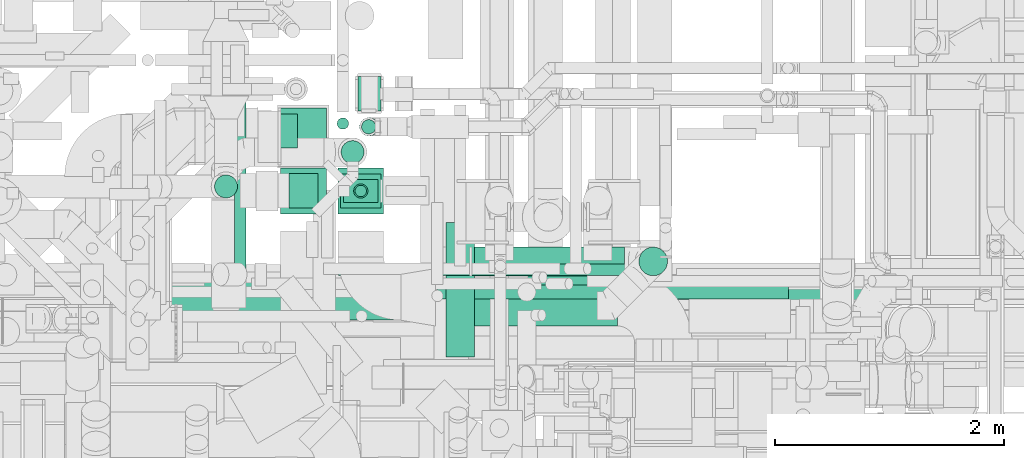
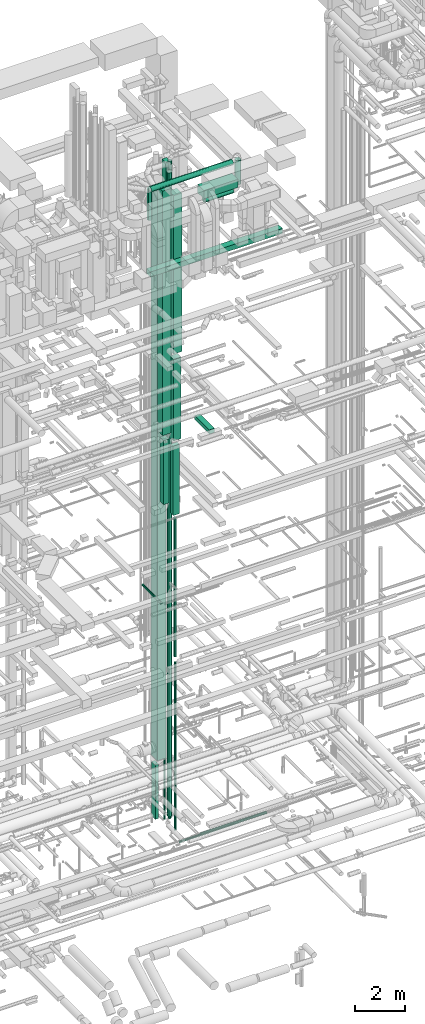
# One storey, part 55 of 337: 24 flow segments.
"""IFC2X3 building model written with IfcOpenShell, lengths in millimetres."""

from ifc_helpers import new_model, entity, si_unit, converted_unit, derived_unit, direction, frame, origin, origin_2d_with_axis, place, context, subcontext, project, spatial, rectangle, circle, extrude, type_object, element, save


model = new_model("IFC2X3")

# Units and contexts
model_context = context("Model", 3, precision=0.01, world=origin(), true_north=direction((6.12303176911189e-17, 1.0)))
body_context = subcontext(model_context, "Body", "Model", "MODEL_VIEW")
ifc_project = project(units=[si_unit("LENGTHUNIT", "METRE", prefix="MILLI"), si_unit("AREAUNIT", "SQUARE_METRE"), si_unit("VOLUMEUNIT", "CUBIC_METRE"), converted_unit("PLANEANGLEUNIT", "DEGREE", entity("IfcRatioMeasure", 0.0174532925199433), si_unit("PLANEANGLEUNIT", "RADIAN"), dimensions=[0, 0, 0, 0, 0, 0, 0]), si_unit("MASSUNIT", "GRAM", prefix="KILO"), derived_unit("MASSDENSITYUNIT", [(si_unit("MASSUNIT", "GRAM", prefix="KILO"), 1), (si_unit("LENGTHUNIT", "METRE"), -3)]), derived_unit("MOMENTOFINERTIAUNIT", [(si_unit("LENGTHUNIT", "METRE"), 4)]), si_unit("TIMEUNIT", "SECOND"), si_unit("FREQUENCYUNIT", "HERTZ"), si_unit("THERMODYNAMICTEMPERATUREUNIT", "DEGREE_CELSIUS"), derived_unit("THERMALTRANSMITTANCEUNIT", [(si_unit("MASSUNIT", "GRAM", prefix="KILO"), 1), (si_unit("THERMODYNAMICTEMPERATUREUNIT", "KELVIN"), -1), (si_unit("TIMEUNIT", "SECOND"), -3)]), derived_unit("VOLUMETRICFLOWRATEUNIT", [(si_unit("LENGTHUNIT", "METRE"), 3), (si_unit("TIMEUNIT", "SECOND"), -1)]), derived_unit("MASSFLOWRATEUNIT", [(si_unit("MASSUNIT", "GRAM", prefix="KILO"), 1), (si_unit("TIMEUNIT", "SECOND"), -1)]), derived_unit("ROTATIONALFREQUENCYUNIT", [(si_unit("TIMEUNIT", "SECOND"), -1)]), si_unit("ELECTRICCURRENTUNIT", "AMPERE"), si_unit("ELECTRICVOLTAGEUNIT", "VOLT"), si_unit("POWERUNIT", "WATT"), si_unit("FORCEUNIT", "NEWTON", prefix="KILO"), si_unit("ILLUMINANCEUNIT", "LUX"), si_unit("LUMINOUSFLUXUNIT", "LUMEN"), si_unit("LUMINOUSINTENSITYUNIT", "CANDELA"), derived_unit("USERDEFINED", [(si_unit("MASSUNIT", "GRAM", prefix="KILO"), -1), (si_unit("LENGTHUNIT", "METRE"), -2), (si_unit("TIMEUNIT", "SECOND"), 3), (si_unit("LUMINOUSFLUXUNIT", "LUMEN"), 1)]), derived_unit("LINEARVELOCITYUNIT", [(si_unit("LENGTHUNIT", "METRE"), 1), (si_unit("TIMEUNIT", "SECOND"), -1)]), si_unit("PRESSUREUNIT", "PASCAL"), derived_unit("USERDEFINED", [(si_unit("LENGTHUNIT", "METRE"), -2), (si_unit("MASSUNIT", "GRAM", prefix="KILO"), 1), (si_unit("TIMEUNIT", "SECOND"), -2)]), derived_unit("LINEARFORCEUNIT", [(si_unit("MASSUNIT", "GRAM", prefix="KILO"), 1), (si_unit("LENGTHUNIT", "METRE"), 1), (si_unit("TIMEUNIT", "SECOND"), -2), (si_unit("LENGTHUNIT", "METRE"), -1)]), derived_unit("PLANARFORCEUNIT", [(si_unit("MASSUNIT", "GRAM", prefix="KILO"), 1), (si_unit("LENGTHUNIT", "METRE"), 1), (si_unit("TIMEUNIT", "SECOND"), -2), (si_unit("LENGTHUNIT", "METRE"), -2)])], contexts=[model_context])

# Site, building, storey
site_placement = place(None, origin())
site = spatial("IfcSite", under=ifc_project, at=site_placement, CompositionType="ELEMENT")
building_placement = place(site_placement, origin())
building = spatial("IfcBuilding", under=site, at=building_placement, CompositionType="ELEMENT")
storey_placement = place(building_placement, origin())
storey = spatial("IfcBuildingStorey", under=building, at=storey_placement, CompositionType="ELEMENT", Elevation=0.0)

# Flow segments
duct_segment_type_1 = type_object("IfcDuctSegmentType", PredefinedType="NOTDEFINED")
flow_segment_1_placement = place(storey_placement, frame((59455.69, 11664.2, 14862.21)))
element("IfcFlowSegment", 1, at=flow_segment_1_placement, inside=storey, type_object=duct_segment_type_1, context=body_context, shape_type="SweptSolid", body=[
    extrude(rectangle(XDim=300.000000000001, YDim=199.999999999998, at=origin_2d_with_axis()), frame((100.0, 150.0, 0.0), z_axis=(0.0, 0.0, 1.0), x_axis=(0.0, -1.0, 0.0)), (0.0, 0.0, 1.0), 16612.7853303961),
])
flow_segment_2_placement = place(storey_placement, frame((59330.56, 10864.63, 14665.0)))
element("IfcFlowSegment", 2, at=flow_segment_2_placement, inside=storey, type_object=duct_segment_type_1, context=body_context, shape_type="SweptSolid", body=[
    extrude(rectangle(XDim=200.000000000002, YDim=300.000000000001, at=origin_2d_with_axis()), frame((150.0, 100.0, 0.0), z_axis=(0.0, 0.0, 1.0), x_axis=(0.0, 1.0, 0.0)), (0.0, 0.0, 1.0), 3400.00000000005),
])
flow_segment_3_placement = place(storey_placement, frame((59305.56, 10814.63, 18365.0)))
element("IfcFlowSegment", 3, at=flow_segment_3_placement, inside=storey, type_object=duct_segment_type_1, context=body_context, shape_type="SweptSolid", body=[
    extrude(rectangle(XDim=299.999999999999, YDim=349.999999999998, at=origin_2d_with_axis()), frame((175.0, 150.0, 0.0), z_axis=(0.0, 0.0, 1.0), x_axis=(0.0, -1.0, 0.0)), (0.0, 0.0, 1.0), 4000.0),
])
flow_segment_4_placement = place(storey_placement, frame((59280.56, 10764.63, 22665.0)))
element("IfcFlowSegment", 4, at=flow_segment_4_placement, inside=storey, type_object=duct_segment_type_1, context=body_context, shape_type="SweptSolid", body=[
    extrude(rectangle(XDim=400.0, YDim=399.999999999996, at=origin_2d_with_axis()), frame((200.0, 200.0, 0.0), z_axis=(0.0, 0.0, 1.0), x_axis=(0.0, 1.0, 0.0)), (0.0, 0.0, 1.0), 7785.00000000005),
])
flow_segment_5_placement = place(storey_placement, frame((60224.84, 9515.12, 19175.0)))
element("IfcFlowSegment", 5, at=flow_segment_5_placement, inside=storey, type_object=duct_segment_type_1, context=body_context, shape_type="SweptSolid", body=[
    extrude(rectangle(XDim=1175.51081891538, YDim=250.000000000004, at=origin_2d_with_axis()), frame((125.0, 587.76, 0.0), z_axis=(0.0, 0.0, 1.0), x_axis=(0.0, -1.0, 0.0)), (0.0, 0.0, 1.0), 199.999999999998),
])
flow_segment_6_placement = place(storey_placement, frame((57735.52, 9932.41, 27500.0)))
element("IfcFlowSegment", 6, at=flow_segment_6_placement, inside=storey, type_object=duct_segment_type_1, context=body_context, shape_type="SweptSolid", body=[
    extrude(rectangle(XDim=6129.99999999986, YDim=299.999999999999, at=origin_2d_with_axis()), frame((3065.0, 150.0, 0.0)), (0.0, 0.0, 1.0), 250.000000000004),
])
flow_segment_7_placement = place(storey_placement, frame((60130.56, 9787.5, 30600.0)))
element("IfcFlowSegment", 7, at=flow_segment_7_placement, inside=storey, type_object=duct_segment_type_1, context=body_context, shape_type="SweptSolid", body=[
    extrude(rectangle(XDim=1589.47570005678, YDim=499.999999999999, at=origin_2d_with_axis()), frame((794.74, 250.0, 0.0)), (0.0, 0.0, 1.0), 399.999999999996),
])
flow_segment_8_placement = place(storey_placement, frame((58780.38, 10765.63, 18844.46)))
element("IfcFlowSegment", 8, at=flow_segment_8_placement, inside=storey, type_object=duct_segment_type_1, context=body_context, shape_type="SweptSolid", body=[
    extrude(rectangle(XDim=400.000000000007, YDim=400.0, at=origin_2d_with_axis()), frame((200.0, 200.0, 0.0)), (0.0, 0.0, 1.0), 12005.5411833054),
])
flow_segment_9_placement = place(storey_placement, frame((58779.9, 11189.32, 2620.0)))
element("IfcFlowSegment", 9, at=flow_segment_9_placement, inside=storey, type_object=duct_segment_type_1, context=body_context, shape_type="SweptSolid", body=[
    extrude(rectangle(XDim=499.999999999997, YDim=400.0, at=origin_2d_with_axis()), frame((200.01, 250.0, 0.0), z_axis=(-3.89216743378987e-07, 0.0, 1.0), x_axis=(0.0, -1.0, 0.0)), (0.0, 0.0, 1.0), 27930.0045295659),
])
flow_segment_10_placement = place(storey_placement, frame((58779.81, 11337.87, -350.0)))
element("IfcFlowSegment", 10, at=flow_segment_10_placement, inside=storey, type_object=duct_segment_type_1, context=body_context, shape_type="SweptSolid", body=[
    extrude(rectangle(XDim=149.999999999998, YDim=300.000000000001, at=origin_2d_with_axis()), frame((75.0, 150.0, 0.0)), (0.0, 0.0, 1.0), 2670.00002678592),
])
flow_segment_11_placement = place(storey_placement, frame((58855.38, 10815.63, 15400.0)))
element("IfcFlowSegment", 11, at=flow_segment_11_placement, inside=storey, type_object=duct_segment_type_1, context=body_context, shape_type="SweptSolid", body=[
    extrude(rectangle(XDim=249.999999999995, YDim=300.000000000001, at=origin_2d_with_axis()), frame((125.0, 150.0, 0.0)), (0.0, 0.0, 1.0), 3144.45879169654),
])
duct_segment_type_2 = type_object("IfcDuctSegmentType", PredefinedType="NOTDEFINED")
flow_segment_12_placement = place(storey_placement, frame((60145.15, 10019.49, -849.1)))
element("IfcFlowSegment", 12, at=flow_segment_12_placement, inside=storey, type_object=duct_segment_type_2, context=body_context, shape_type="SweptSolid", body=[
    extrude(circle(Radius=62.5, at=origin_2d_with_axis()), frame((0.0, 64.1, 64.1), z_axis=(1.0, 0.0, 0.0), x_axis=(0.0, 1.0, 0.0)), (0.0, 0.0, 1.0), 3067.9582299999),
])
flow_segment_13_placement = place(storey_placement, frame((59307.34, 11202.59, -350.0)))
element("IfcFlowSegment", 13, at=flow_segment_13_placement, inside=storey, type_object=duct_segment_type_2, context=body_context, shape_type="SweptSolid", body=[
    extrude(circle(Radius=100.0, at=origin_2d_with_axis()), frame((101.6, 101.6, 0.0), z_axis=(0.0, 0.0, 1.0), x_axis=(-1.0, 0.0, 0.0)), (0.0, 0.0, 1.0), 31619.5965842715),
])
flow_segment_14_placement = place(storey_placement, frame((59286.81, 10227.1, -1026.6)))
element("IfcFlowSegment", 14, at=flow_segment_14_placement, inside=storey, type_object=duct_segment_type_2, context=body_context, shape_type="SweptSolid", body=[
    extrude(circle(Radius=50.0, at=origin_2d_with_axis()), frame((0.0, 51.6, 51.6), z_axis=(1.0, 0.0, 0.0), x_axis=(0.0, -1.0, 0.0)), (0.0, 0.0, 1.0), 2753.45116999999),
])
flow_segment_15_placement = place(storey_placement, frame((58375.69, 10255.6, 10998.4)))
element("IfcFlowSegment", 15, at=flow_segment_15_placement, inside=storey, type_object=duct_segment_type_2, context=body_context, shape_type="SweptSolid", body=[
    extrude(circle(Radius=50.0, at=origin_2d_with_axis()), frame((51.6, 0.0, 51.6), z_axis=(0.0, 1.0, 0.0), x_axis=(1.0, 0.0, 0.0)), (0.0, 0.0, 1.0), 1498.62851561006),
])
flow_segment_16_placement = place(storey_placement, frame((59485.89, 11460.8, -660.0)))
element("IfcFlowSegment", 16, at=flow_segment_16_placement, inside=storey, type_object=duct_segment_type_2, context=body_context, shape_type="SweptSolid", body=[
    extrude(circle(Radius=62.5, at=origin_2d_with_axis()), frame((64.1, 64.1, 0.0), z_axis=(-1.77429412138521e-06, 0.0, 1.0), x_axis=(-1.0, 0.0, -1.77429412138521e-06)), (0.0, 0.0, 1.0), 3955.00000070971),
])
flow_segment_17_placement = place(storey_placement, frame((59428.96, 10913.04, -875.0)))
element("IfcFlowSegment", 17, at=flow_segment_17_placement, inside=storey, type_object=duct_segment_type_2, context=body_context, shape_type="SweptSolid", body=[
    extrude(circle(Radius=50.0, at=origin_2d_with_axis()), frame((51.6, 51.6, 0.0), z_axis=(0.0, 0.0, 1.0), x_axis=(0.0, -1.0, 0.0)), (0.0, 0.0, 1.0), 8240.00000000002),
])
flow_segment_18_placement = place(storey_placement, frame((59416.46, 10900.54, 7650.0)))
element("IfcFlowSegment", 18, at=flow_segment_18_placement, inside=storey, type_object=duct_segment_type_2, context=body_context, shape_type="SweptSolid", body=[
    extrude(circle(Radius=62.5, at=origin_2d_with_axis()), frame((64.1, 64.1, 0.0)), (0.0, 0.0, 1.0), 6815.00000000002),
])
flow_segment_19_placement = place(storey_placement, frame((57734.08, 9838.14, 31673.4)))
element("IfcFlowSegment", 19, at=flow_segment_19_placement, inside=storey, type_object=duct_segment_type_2, context=body_context, shape_type="SweptSolid", body=[
    extrude(circle(Radius=125.0, at=origin_2d_with_axis()), frame((0.0, 126.6, 126.6), z_axis=(1.0, 0.0, 0.0), x_axis=(0.0, -1.0, 0.0)), (0.0, 0.0, 1.0), 3808.88033491606),
])
flow_segment_20_placement = place(storey_placement, frame((61905.38, 10223.59, 30350.0)))
element("IfcFlowSegment", 20, at=flow_segment_20_placement, inside=storey, type_object=duct_segment_type_2, context=body_context, shape_type="SweptSolid", body=[
    extrude(circle(Radius=125.0, at=origin_2d_with_axis()), frame((126.6, 126.6, 0.0), z_axis=(0.0, 0.0, 1.0), x_axis=(0.707106781186555, -0.70710678118654, 0.0)), (0.0, 0.0, 1.0), 1200.00000000001),
])
flow_segment_21_placement = place(storey_placement, frame((60451.97, 10223.59, 29973.4)))
element("IfcFlowSegment", 21, at=flow_segment_21_placement, inside=storey, type_object=duct_segment_type_2, context=body_context, shape_type="SweptSolid", body=[
    extrude(circle(Radius=125.0, at=origin_2d_with_axis()), frame((0.0, 126.6, 126.6), z_axis=(1.0, 0.0, 0.0), x_axis=(0.0, 1.0, 0.0)), (0.0, 0.0, 1.0), 1330.00000000002),
])
flow_segment_22_placement = place(storey_placement, frame((58203.44, 10902.63, 29500.0)))
element("IfcFlowSegment", 22, at=flow_segment_22_placement, inside=storey, type_object=duct_segment_type_2, context=body_context, shape_type="SweptSolid", body=[
    extrude(circle(Radius=100.0, at=origin_2d_with_axis()), frame((101.6, 101.6, 0.0), z_axis=(0.0, 0.0, 1.0), x_axis=(-1.0, 0.0, 0.0)), (0.0, 0.0, 1.0), 1517.15730536777),
])
flow_segment_23_placement = place(storey_placement, frame((59468.4, 11443.3, 3329.98)))
element("IfcFlowSegment", 23, at=flow_segment_23_placement, inside=storey, type_object=duct_segment_type_2, context=body_context, shape_type="SweptSolid", body=[
    extrude(circle(Radius=80.0, at=origin_2d_with_axis()), frame((81.6, 81.6, 0.02), z_axis=(0.000200495235506447, 0.0, 0.99999997990083), x_axis=(0.0, 1.0, 0.0)), (0.0, 0.0, 1.0), 28310.0326476144),
])
flow_segment_24_placement = place(storey_placement, frame((59272.94, 11501.46, -650.0)))
element("IfcFlowSegment", 24, at=flow_segment_24_placement, inside=storey, type_object=duct_segment_type_2, context=body_context, shape_type="SweptSolid", body=[
    extrude(circle(Radius=50.0, at=origin_2d_with_axis()), frame((51.6, 51.6, 0.0)), (0.0, 0.0, 1.0), 29150.0),
])

save(model, "model.ifc")
